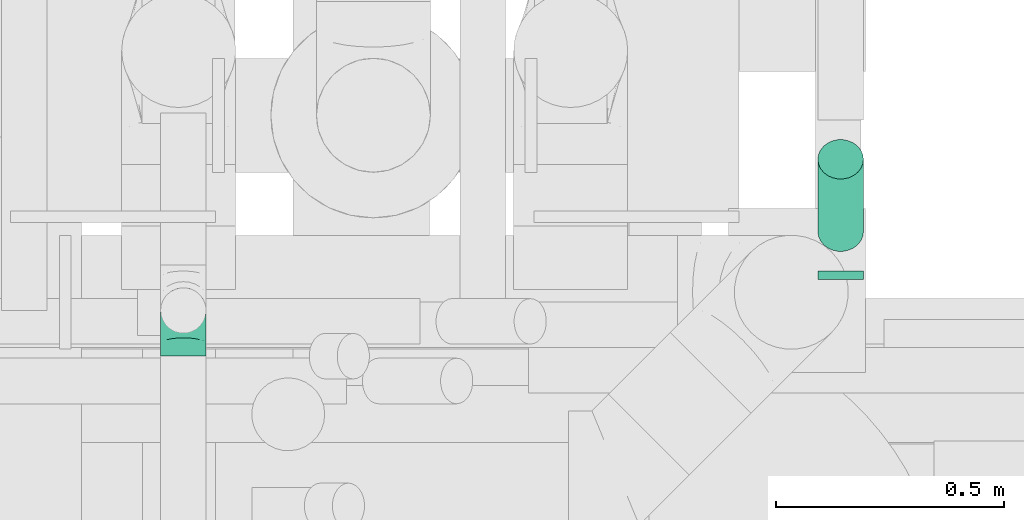
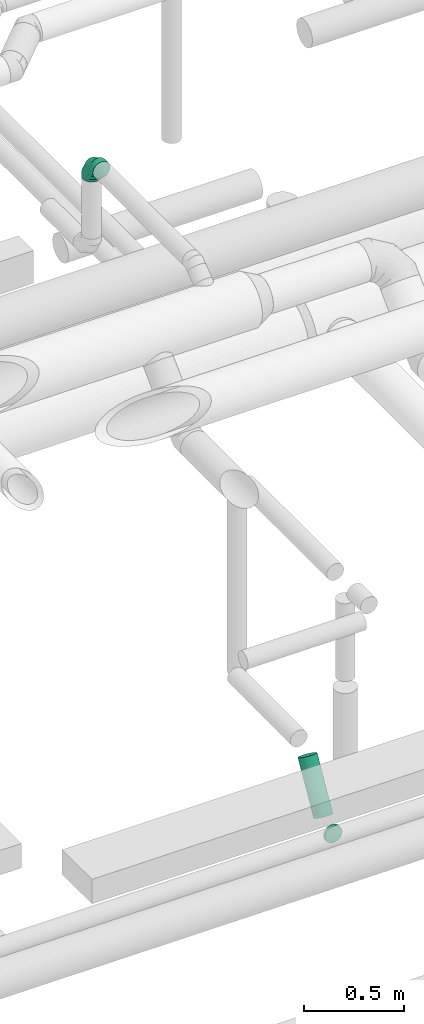
# One storey, part 241 of 337: 2 flow segments, 1 flow fitting.
"""IFC2X3 building model written with IfcOpenShell, lengths in millimetres."""

from ifc_helpers import new_model, entity, si_unit, converted_unit, derived_unit, direction, frame, origin, origin_2d_with_axis, place, context, subcontext, project, spatial, circle, extrude, faceted_brep, source, transform, mapped, material, type_object, type_shapes, element, save


model = new_model("IFC2X3")

# Units and contexts
model_context = context("Model", 3, precision=0.01, world=origin(), true_north=direction((6.12303176911189e-17, 1.0)))
body_context = subcontext(model_context, "Body", "Model", "MODEL_VIEW")
ifc_project = project(units=[si_unit("LENGTHUNIT", "METRE", prefix="MILLI"), si_unit("AREAUNIT", "SQUARE_METRE"), si_unit("VOLUMEUNIT", "CUBIC_METRE"), converted_unit("PLANEANGLEUNIT", "DEGREE", entity("IfcRatioMeasure", 0.0174532925199433), si_unit("PLANEANGLEUNIT", "RADIAN"), dimensions=[0, 0, 0, 0, 0, 0, 0]), si_unit("MASSUNIT", "GRAM", prefix="KILO"), derived_unit("MASSDENSITYUNIT", [(si_unit("MASSUNIT", "GRAM", prefix="KILO"), 1), (si_unit("LENGTHUNIT", "METRE"), -3)]), derived_unit("MOMENTOFINERTIAUNIT", [(si_unit("LENGTHUNIT", "METRE"), 4)]), si_unit("TIMEUNIT", "SECOND"), si_unit("FREQUENCYUNIT", "HERTZ"), si_unit("THERMODYNAMICTEMPERATUREUNIT", "DEGREE_CELSIUS"), derived_unit("THERMALTRANSMITTANCEUNIT", [(si_unit("MASSUNIT", "GRAM", prefix="KILO"), 1), (si_unit("THERMODYNAMICTEMPERATUREUNIT", "KELVIN"), -1), (si_unit("TIMEUNIT", "SECOND"), -3)]), derived_unit("VOLUMETRICFLOWRATEUNIT", [(si_unit("LENGTHUNIT", "METRE"), 3), (si_unit("TIMEUNIT", "SECOND"), -1)]), derived_unit("MASSFLOWRATEUNIT", [(si_unit("MASSUNIT", "GRAM", prefix="KILO"), 1), (si_unit("TIMEUNIT", "SECOND"), -1)]), derived_unit("ROTATIONALFREQUENCYUNIT", [(si_unit("TIMEUNIT", "SECOND"), -1)]), si_unit("ELECTRICCURRENTUNIT", "AMPERE"), si_unit("ELECTRICVOLTAGEUNIT", "VOLT"), si_unit("POWERUNIT", "WATT"), si_unit("FORCEUNIT", "NEWTON", prefix="KILO"), si_unit("ILLUMINANCEUNIT", "LUX"), si_unit("LUMINOUSFLUXUNIT", "LUMEN"), si_unit("LUMINOUSINTENSITYUNIT", "CANDELA"), derived_unit("USERDEFINED", [(si_unit("MASSUNIT", "GRAM", prefix="KILO"), -1), (si_unit("LENGTHUNIT", "METRE"), -2), (si_unit("TIMEUNIT", "SECOND"), 3), (si_unit("LUMINOUSFLUXUNIT", "LUMEN"), 1)]), derived_unit("LINEARVELOCITYUNIT", [(si_unit("LENGTHUNIT", "METRE"), 1), (si_unit("TIMEUNIT", "SECOND"), -1)]), si_unit("PRESSUREUNIT", "PASCAL"), derived_unit("USERDEFINED", [(si_unit("LENGTHUNIT", "METRE"), -2), (si_unit("MASSUNIT", "GRAM", prefix="KILO"), 1), (si_unit("TIMEUNIT", "SECOND"), -2)]), derived_unit("LINEARFORCEUNIT", [(si_unit("MASSUNIT", "GRAM", prefix="KILO"), 1), (si_unit("LENGTHUNIT", "METRE"), 1), (si_unit("TIMEUNIT", "SECOND"), -2), (si_unit("LENGTHUNIT", "METRE"), -1)]), derived_unit("PLANARFORCEUNIT", [(si_unit("MASSUNIT", "GRAM", prefix="KILO"), 1), (si_unit("LENGTHUNIT", "METRE"), 1), (si_unit("TIMEUNIT", "SECOND"), -2), (si_unit("LENGTHUNIT", "METRE"), -2)])], contexts=[model_context])

# Site, building, storey
site_placement = place(None, origin())
site = spatial("IfcSite", under=ifc_project, at=site_placement, CompositionType="ELEMENT")
building_placement = place(site_placement, origin())
building = spatial("IfcBuilding", under=site, at=building_placement, CompositionType="ELEMENT")
storey_placement = place(building_placement, origin())
storey = spatial("IfcBuildingStorey", under=building, at=storey_placement, CompositionType="ELEMENT", Elevation=0.0)

# Flow segments
duct_segment_type = type_object("IfcDuctSegmentType", PredefinedType="NOTDEFINED")
flow_segment_1_placement = place(storey_placement, frame((62088.67, 10378.7, -1026.6)))
element("IfcFlowSegment", 1, at=flow_segment_1_placement, inside=storey, type_object=duct_segment_type, context=body_context, shape_type="SweptSolid", body=[
    extrude(circle(Radius=50.0, at=origin_2d_with_axis()), frame((51.6, 0.0, 51.6), z_axis=(0.0, 1.0, 0.0), x_axis=(1.0, 0.0, 0.0)), (0.0, 0.0, 1.0), 17.7819505943875),
])
flow_segment_2_placement = place(storey_placement, frame((62088.67, 10438.19, -951.6)))
element("IfcFlowSegment", 2, at=flow_segment_2_placement, inside=storey, type_object=duct_segment_type, context=body_context, shape_type="SweptSolid", body=[
    extrude(circle(Radius=50.0, at=origin_2d_with_axis()), frame((51.6, 44.9, 26.6), z_axis=(0.0, 0.499999999999966, 0.866025403784458), x_axis=(1.0, 0.0, 0.0)), (0.0, 0.0, 1.0), 317.542685067887),
])

# Flow fitting
ifc_material = material()
duct_fitting_type = type_object("IfcDuctFittingType", PredefinedType="NOTDEFINED", material=ifc_material)
shared_shape = source(origin(), body_context, "Body", "Brep", [
    faceted_brep([(-100.0, 0.0, -50.0), (-100.0, -12.94, -48.3), (-100.0, -25.0, -43.3), (-100.0, -35.36, -35.36), (-100.0, -43.3, -25.0), (-100.0, -48.3, -12.94), (-100.0, -50.0, 0.0), (-100.0, -48.3, 12.94), (-100.0, -43.3, 25.0), (-100.0, -35.36, 35.36), (-100.0, -25.0, 43.3), (-100.0, -12.94, 48.3), (-100.0, 0.0, 50.0), (-100.0, 12.94, 48.3), (-100.0, 25.0, 43.3), (-100.0, 35.36, 35.36), (-100.0, 43.3, 25.0), (-100.0, 48.3, 12.94), (-100.0, 50.0, 0.0), (-100.0, 48.3, -12.94), (-100.0, 43.3, -25.0), (-100.0, 35.36, -35.36), (-100.0, 25.0, -43.3), (-100.0, 12.94, -48.3), (-76.67, 12.94, 48.3), (-79.9, 25.0, 43.3), (-73.21, 0.0, 50.0), (-82.68, 35.36, 35.36), (-86.15, 48.3, 12.94), (-86.6, 50.0, 0.0), (-84.81, 43.3, 25.0), (-84.81, 43.3, -25.0), (-82.68, 35.36, -35.36), (-86.15, 48.3, -12.94), (-76.67, 12.94, -48.3), (-73.21, 0.0, -50.0), (-79.9, 25.0, -43.3), (-69.74, -12.94, -48.3), (-66.51, -25.0, -43.3), (-63.73, -35.36, -35.36), (-61.6, -43.3, -25.0), (-60.26, -48.3, -12.94), (-59.81, -50.0, 0.0), (-60.26, -48.3, 12.94), (-61.6, -43.3, 25.0), (-63.73, -35.36, 35.36), (-66.51, -25.0, 43.3), (-69.74, -12.94, 48.3), (-36.27, 36.27, 48.3), (-45.1, 45.1, 43.3), (-26.79, 26.79, 50.0), (-52.68, 52.68, 35.36), (-58.49, 58.49, 25.0), (-62.15, 62.15, 12.94), (-63.4, 63.4, 0.0), (-62.15, 62.15, -12.94), (-58.49, 58.49, -25.0), (-52.68, 52.68, -35.36), (-36.27, 36.27, -48.3), (-26.79, 26.79, -50.0), (-45.1, 45.1, -43.3), (-17.32, 17.32, -48.3), (-8.49, 8.49, -43.3), (-0.91, 0.91, -35.36), (4.9, -4.9, -25.0), (8.56, -8.56, -12.94), (9.81, -9.81, 0.0), (8.56, -8.56, 12.94), (4.9, -4.9, 25.0), (-0.91, 0.91, 35.36), (-8.49, 8.49, 43.3), (-17.32, 17.32, 48.3), (-12.94, 76.67, 48.3), (-25.0, 79.9, 43.3), (0.0, 73.21, 50.0), (-35.36, 82.68, 35.36), (-43.3, 84.81, 25.0), (-48.3, 86.15, 12.94), (-50.0, 86.6, 0.0), (-48.3, 86.15, -12.94), (-43.3, 84.81, -25.0), (-35.36, 82.68, -35.36), (-12.94, 76.67, -48.3), (0.0, 73.21, -50.0), (-25.0, 79.9, -43.3), (12.94, 69.74, -48.3), (25.0, 66.51, -43.3), (35.36, 63.73, -35.36), (43.3, 61.6, -25.0), (48.3, 60.26, -12.94), (50.0, 59.81, 0.0), (48.3, 60.26, 12.94), (43.3, 61.6, 25.0), (35.36, 63.73, 35.36), (25.0, 66.51, 43.3), (12.94, 69.74, 48.3), (-12.94, 100.0, -48.3), (-25.0, 100.0, -43.3), (-35.36, 100.0, -35.36), (-43.3, 100.0, -25.0), (-48.3, 100.0, -12.94), (-50.0, 100.0, 0.0), (-48.3, 100.0, 12.94), (-43.3, 100.0, 25.0), (-35.36, 100.0, 35.36), (-25.0, 100.0, 43.3), (-12.94, 100.0, 48.3), (0.0, 100.0, 50.0), (12.94, 100.0, 48.3), (25.0, 100.0, 43.3), (35.36, 100.0, 35.36), (43.3, 100.0, 25.0), (48.3, 100.0, 12.94), (50.0, 100.0, 0.0), (48.3, 100.0, -12.94), (43.3, 100.0, -25.0), (35.36, 100.0, -35.36), (25.0, 100.0, -43.3), (12.94, 100.0, -48.3), (0.0, 100.0, -50.0)], [[[0, 1, 2, 3, 4, 5, 6, 7, 8, 9, 10, 11, 12, 13, 14, 15, 16, 17, 18, 19, 20, 21, 22, 23]], [[24, 25, 14, 13]], [[26, 24, 13, 12]], [[14, 25, 27, 15]], [[28, 29, 18, 17]], [[30, 28, 17, 16]], [[15, 27, 30, 16]], [[20, 31, 32, 21]], [[33, 31, 20, 19]], [[18, 29, 33, 19]], [[34, 35, 0, 23]], [[36, 34, 23, 22]], [[32, 36, 22, 21]], [[2, 1, 37, 38]], [[3, 2, 38, 39]], [[0, 35, 37, 1]], [[5, 4, 40, 41]], [[6, 5, 41, 42]], [[3, 39, 40, 4]], [[6, 42, 43, 7]], [[7, 43, 44, 8]], [[8, 44, 45, 9]], [[10, 46, 47, 11]], [[11, 47, 26, 12]], [[10, 9, 45, 46]], [[48, 49, 25, 24]], [[50, 48, 24, 26]], [[27, 25, 49, 51]], [[52, 53, 28, 30]], [[51, 52, 30, 27]], [[29, 28, 53, 54]], [[55, 56, 31, 33]], [[54, 55, 33, 29]], [[57, 32, 31, 56]], [[58, 59, 35, 34]], [[60, 58, 34, 36]], [[57, 60, 36, 32]], [[37, 35, 59, 61]], [[38, 37, 61, 62]], [[39, 38, 62, 63]], [[41, 40, 64, 65]], [[42, 41, 65, 66]], [[63, 64, 40, 39]], [[43, 42, 66, 67]], [[44, 43, 67, 68]], [[68, 69, 45, 44]], [[46, 45, 69, 70]], [[47, 46, 70, 71]], [[26, 47, 71, 50]], [[72, 73, 49, 48]], [[74, 72, 48, 50]], [[51, 49, 73, 75]], [[76, 77, 53, 52]], [[75, 76, 52, 51]], [[54, 53, 77, 78]], [[79, 80, 56, 55]], [[78, 79, 55, 54]], [[81, 57, 56, 80]], [[82, 83, 59, 58]], [[84, 82, 58, 60]], [[81, 84, 60, 57]], [[61, 59, 83, 85]], [[62, 61, 85, 86]], [[63, 62, 86, 87]], [[65, 64, 88, 89]], [[66, 65, 89, 90]], [[87, 88, 64, 63]], [[67, 66, 90, 91]], [[68, 67, 91, 92]], [[92, 93, 69, 68]], [[70, 69, 93, 94]], [[71, 70, 94, 95]], [[50, 71, 95, 74]], [[96, 97, 98, 99, 100, 101, 102, 103, 104, 105, 106, 107, 108, 109, 110, 111, 112, 113, 114, 115, 116, 117, 118, 119]], [[72, 74, 107, 106]], [[73, 72, 106, 105]], [[75, 73, 105, 104]], [[77, 76, 103, 102]], [[78, 77, 102, 101]], [[75, 104, 103, 76]], [[78, 101, 100, 79]], [[79, 100, 99, 80]], [[80, 99, 98, 81]], [[96, 119, 83, 82]], [[97, 96, 82, 84]], [[84, 81, 98, 97]], [[83, 119, 118, 85]], [[85, 118, 117, 86]], [[86, 117, 116, 87]], [[88, 115, 114, 89]], [[89, 114, 113, 90]], [[87, 116, 115, 88]], [[91, 90, 113, 112]], [[92, 91, 112, 111]], [[93, 92, 111, 110]], [[95, 94, 109, 108]], [[74, 95, 108, 107]], [[110, 109, 94, 93]]]),
])
type_shapes(duct_fitting_type, [shared_shape])
flow_fitting_placement = place(storey_placement, frame((60698.4, 10310.09, 3700.0), z_axis=(1.0, 0.0, 0.0), x_axis=(0.0, 0.0, 1.0)))
element("IfcFlowFitting", 3, at=flow_fitting_placement, inside=storey, type_object=duct_fitting_type, material=ifc_material, context=body_context, shape_type="MappedRepresentation", body=[
    mapped(shared_shape, transform((0.0, 0.0, 0.0), scale=1.0)),
])

save(model, "model.ifc")
